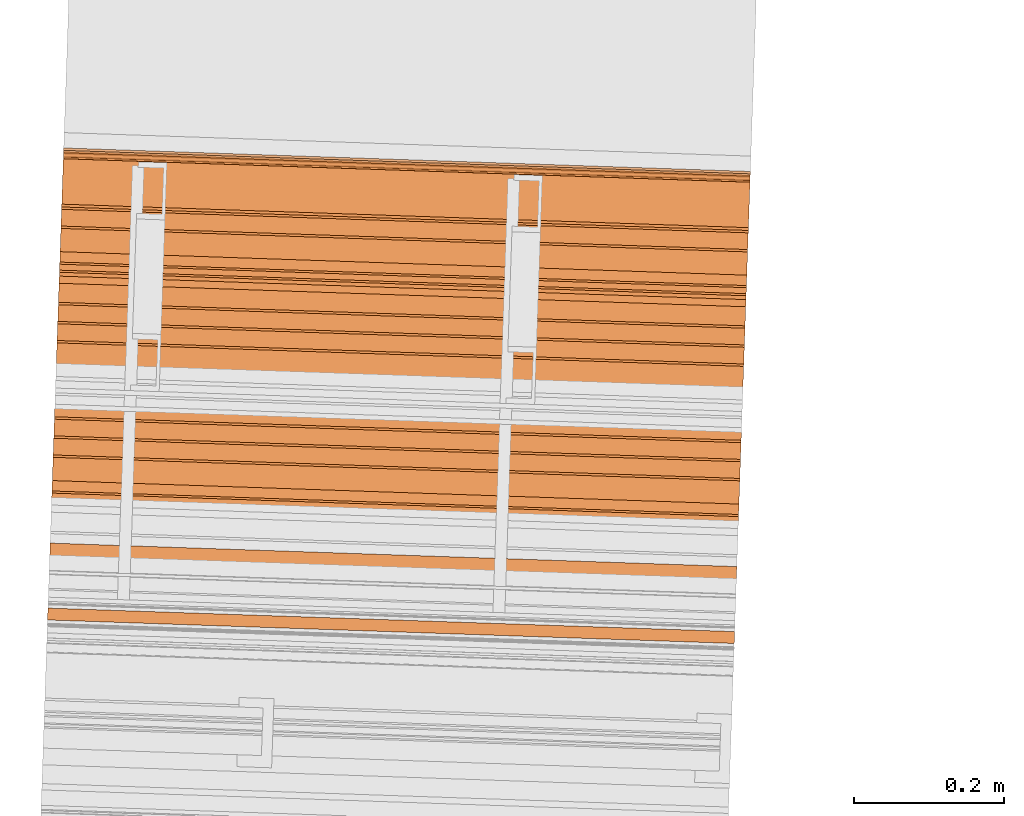
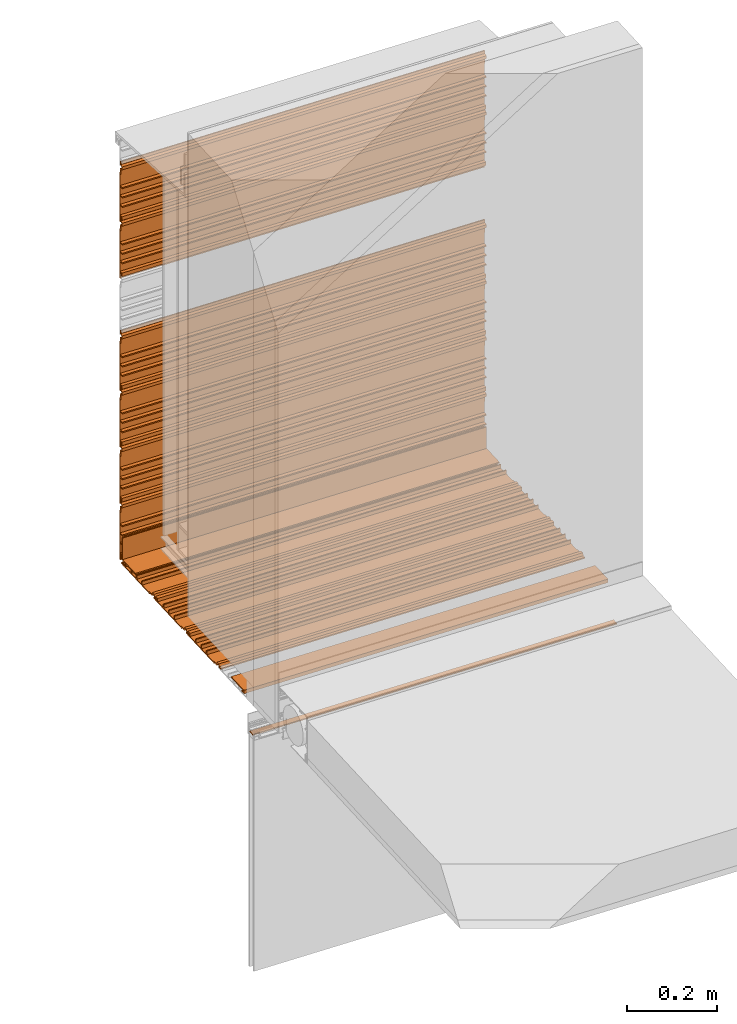
# One storey, part 10 of 36: 13 proxies.
"""IFC2X3 building model written with IfcOpenShell, lengths in feet."""

from ifc_helpers import new_model, entity, si_unit, converted_unit, derived_unit, direction, frame, frame_2d, origin, place, context, subcontext, project, spatial, polyline, circle_curve, parameter, trimmed, segment, composite_curve, outline, extrude, source, transform, mapped, material, type_object, type_shapes, element, save


model = new_model("IFC2X3")

# Units and contexts
model_context = context("Model", 3, precision=0.0001, world=origin(), true_north=direction((6.12303176911189e-17, 1.0)))
body_context = subcontext(model_context, "Body", "Model", "MODEL_VIEW")
ifc_project = project(units=[converted_unit("LENGTHUNIT", "FOOT", entity("IfcRatioMeasure", 0.3048), si_unit("LENGTHUNIT", "METRE"), dimensions=[1, 0, 0, 0, 0, 0, 0]), converted_unit("AREAUNIT", "SQUARE FOOT", entity("IfcRatioMeasure", 0.09290304), si_unit("AREAUNIT", "SQUARE_METRE"), dimensions=[2, 0, 0, 0, 0, 0, 0]), converted_unit("VOLUMEUNIT", "CUBIC FOOT", entity("IfcRatioMeasure", 0.028316846592), si_unit("VOLUMEUNIT", "CUBIC_METRE"), dimensions=[3, 0, 0, 0, 0, 0, 0]), converted_unit("PLANEANGLEUNIT", "DEGREE", entity("IfcRatioMeasure", 0.0174532925199433), si_unit("PLANEANGLEUNIT", "RADIAN"), dimensions=[0, 0, 0, 0, 0, 0, 0]), si_unit("MASSUNIT", "GRAM", prefix="KILO"), derived_unit("MASSDENSITYUNIT", [(si_unit("MASSUNIT", "GRAM", prefix="KILO"), 1), (si_unit("LENGTHUNIT", "METRE"), -3)]), si_unit("TIMEUNIT", "SECOND"), si_unit("FREQUENCYUNIT", "HERTZ"), si_unit("THERMODYNAMICTEMPERATUREUNIT", "DEGREE_CELSIUS"), derived_unit("THERMALTRANSMITTANCEUNIT", [(si_unit("MASSUNIT", "GRAM", prefix="KILO"), 1), (si_unit("THERMODYNAMICTEMPERATUREUNIT", "KELVIN"), -1), (si_unit("TIMEUNIT", "SECOND"), -3)]), derived_unit("VOLUMETRICFLOWRATEUNIT", [(si_unit("LENGTHUNIT", "METRE"), 3), (si_unit("TIMEUNIT", "SECOND"), -1)]), si_unit("ELECTRICCURRENTUNIT", "AMPERE"), si_unit("ELECTRICVOLTAGEUNIT", "VOLT"), si_unit("POWERUNIT", "WATT"), si_unit("FORCEUNIT", "NEWTON"), si_unit("ILLUMINANCEUNIT", "LUX"), si_unit("LUMINOUSFLUXUNIT", "LUMEN"), si_unit("LUMINOUSINTENSITYUNIT", "CANDELA"), derived_unit("USERDEFINED", [(si_unit("MASSUNIT", "GRAM", prefix="KILO"), -1), (si_unit("LENGTHUNIT", "METRE"), -2), (si_unit("TIMEUNIT", "SECOND"), 3), (si_unit("LUMINOUSFLUXUNIT", "LUMEN"), 1)]), derived_unit("LINEARVELOCITYUNIT", [(si_unit("LENGTHUNIT", "METRE"), 1), (si_unit("TIMEUNIT", "SECOND"), -1)]), si_unit("PRESSUREUNIT", "PASCAL"), derived_unit("USERDEFINED", [(si_unit("LENGTHUNIT", "METRE"), -2), (si_unit("MASSUNIT", "GRAM", prefix="KILO"), 1), (si_unit("TIMEUNIT", "SECOND"), -2)])], contexts=[model_context])

# Site, building, storey
site_placement = place(None, origin())
site = spatial("IfcSite", under=ifc_project, at=site_placement, CompositionType="ELEMENT")
building_placement = place(site_placement, origin())
building = spatial("IfcBuilding", under=site, at=building_placement, CompositionType="ELEMENT")
storey_placement = place(building_placement, origin())
storey = spatial("IfcBuildingStorey", under=building, at=storey_placement, Name="Level 1", CompositionType="ELEMENT", Elevation=0.0)

# Proxies
ifc_material_1 = material()
building_element_proxy_type_1 = type_object("IfcBuildingElementProxyType", Name="panel 018", PredefinedType="NOTDEFINED", material=ifc_material_1)
shared_shape_1 = source(origin(), body_context, "Body", "SweptSolid", [
    extrude(outline(polyline([(-0.291819852941191, -0.0116008650030945), (-0.291819852941191, -0.0220175316697464), (0.145680147058831, -0.0220175316697464), (0.145680147058831, -0.0116008650030945), (0.187346813725472, -0.0116008650030945), (0.195644309526004, 0.00619317207041625), (0.210299317924962, 0.00619317207041625), (0.218596813725494, -0.0116008650030945), (0.249846813725516, -0.0116008650030945), (0.249846813725516, -0.00118419833641603), (0.225232962281921, -0.00118419833641603), (0.21599402661919, 0.0186287629496658), (0.189949600831798, 0.0186287629496658), (0.180710665169066, -0.00118419833641603), (0.135263480392155, -0.00118419833641603), (0.135263480392155, -0.0116008650030945), (0.0337009803921422, -0.0116008650030945), (0.0337009803921422, 0.0196491349969126), (0.0232843137254944, 0.0196491349969126), (0.0232843137254944, -0.0116008650030945), (-0.0496323529411691, -0.0116008650030945), (-0.0496323529411691, 0.0196491349969126), (-0.0600490196078453, 0.0196491349969126), (-0.0600490196078453, -0.0116008650030945), (-0.132965686274508, -0.0116008650030945), (-0.132965686274508, 0.0196491349969126), (-0.143382352941185, 0.0196491349969126), (-0.143382352941185, -0.0116008650030945), (-0.226715686274524, -0.0116008650030945), (-0.226715686274524, 0.01730477312028), (-0.257965686274518, 0.01730477312028), (-0.257965686274518, 0.00451787023312988), (-0.237132352941172, 0.00451787023312988), (-0.237132352941172, -0.0116008650030945), (-0.291819852941191, -0.0116008650030945)])), frame((109.741606113486, -49.8662291822322, 9.73037350903194), z_axis=(-0.999414947916631, 0.0342017818365886, 0.0), x_axis=(-0.0342017818365886, -0.999414947916631, 0.0)), (0.0, 0.0, -1.0), 2.99999999999999),
])
type_shapes(building_element_proxy_type_1, [shared_shape_1])
proxy_1_placement = place(storey_placement, origin())
element("IfcBuildingElementProxy", 1, at=proxy_1_placement, inside=storey, type_object=building_element_proxy_type_1, material=ifc_material_1, Name="panel 018:panel 018", ObjectType="panel 018", context=body_context, shape_type="MappedRepresentation", body=[
    mapped(shared_shape_1, transform((0.0, 0.0, 0.0), scale=1.0)),
])
ifc_material_2 = material(Name="Window frame")
building_element_proxy_type_2 = type_object("IfcBuildingElementProxyType", Name="Window frame 013", PredefinedType="NOTDEFINED", material=ifc_material_2)
shared_shape_2 = source(origin(), body_context, "Body", "SweptSolid", [
    extrude(outline(composite_curve([segment(polyline([(-0.00499999999991374, -0.0259583333333165), (0.00499999999991552, -0.0259583333333165)]), True, "CONTINUOUS"), segment(polyline([(0.00499999999991552, -0.0259583333333165), (0.00499999999991552, 0.0259583333333232)]), True, "CONTINUOUS"), segment(polyline([(0.00499999999991552, 0.0259583333333232), (-0.00499999999991729, 0.0259583333333232)]), True, "CONTINUOUS"), segment(trimmed(circle_curve(frame_2d((-0.138517013888798, 0.0), x_axis=(0.0, 1.0)), 0.13601701388888), [parameter(258.997827097198)], [parameter(281.002172902812)], True, "PARAMETER"), False, "CONTINUOUS")], self_intersect=False)), frame((109.717039781299, -50.5840853372173, 9.44496783238198), z_axis=(0.999414947916633, -0.0342017818365487, 0.0), x_axis=(0.0, 0.0, 1.0)), (0.0, 0.0, 1.0), 3.0),
])
type_shapes(building_element_proxy_type_2, [shared_shape_2])
proxy_2_placement = place(storey_placement, origin())
element("IfcBuildingElementProxy", 2, at=proxy_2_placement, inside=storey, type_object=building_element_proxy_type_2, material=ifc_material_2, Name="Window frame 013:Window frame 013", ObjectType="Window frame 013", context=body_context, shape_type="MappedRepresentation", body=[
    mapped(shared_shape_2, transform((0.0, 0.0, 0.0), scale=1.0)),
])
building_element_proxy_type_3 = type_object("IfcBuildingElementProxyType", Name="panel 015", PredefinedType="NOTDEFINED", material=ifc_material_1)
shared_shape_3 = source(origin(), body_context, "Body", "SweptSolid", [
    extrude(outline(polyline([(-0.02201753168521, 0.145680147068472), (-0.02201753168521, -0.291819852931523), (-0.0116008650185618, -0.291819852931523), (-0.0116008650185618, -0.237132352931534), (0.00451787028329734, -0.237132352931534), (0.00451787028329734, -0.257965686264862), (0.0173047730392111, -0.257965686264862), (0.0173047730392111, -0.226715686264857), (-0.0116008650185618, -0.226715686264857), (-0.0116008650185618, -0.143382352931518), (0.0196491349814615, -0.143382352931518), (0.0196491349814615, -0.132965686264866), (-0.0116008650185618, -0.132965686264866), (-0.0116008650185618, -0.0600490195981802), (0.0196491349814615, -0.0600490195981802), (0.0196491349814615, -0.0496323529315283), (-0.0116008650185618, -0.0496323529315283), (-0.0116008650185618, 0.0232843137351342), (0.0196491349814615, 0.0232843137351342), (0.0196491349814615, 0.0337009804018091), (-0.0116008650185618, 0.0337009804018091), (-0.0116008650185618, 0.135263480401818), (-0.00118419835186385, 0.135263480401818), (-0.00118419835186385, 0.1807106651131), (0.018628763098251, 0.189949600808632), (0.018628763098251, 0.215994026661654), (-0.00118419835186385, 0.2252329620291), (-0.00118419835186385, 0.249846813735138), (-0.0116008650185618, 0.249846813735138), (-0.0116008650185618, 0.218596813735134), (0.0061931721533693, 0.210299318000235), (0.0061931721533693, 0.195644309470051), (-0.0116008650185618, 0.187346813735154), (-0.0116008650185618, 0.145680147068472), (-0.02201753168521, 0.145680147068472)])), frame((109.785926286855, -48.5711433305343, 10.521009163627), z_axis=(-0.999414947916598, 0.0342017818375703, 0.0), x_axis=(-0.0342017818375703, -0.999414947916598, 0.0)), (0.0, 0.0, -1.0), 2.99999999999999),
])
type_shapes(building_element_proxy_type_3, [shared_shape_3])
proxy_3_placement = place(storey_placement, origin())
element("IfcBuildingElementProxy", 3, at=proxy_3_placement, inside=storey, type_object=building_element_proxy_type_3, material=ifc_material_1, Name="panel 015:panel 015", ObjectType="panel 015", context=body_context, shape_type="MappedRepresentation", body=[
    mapped(shared_shape_3, transform((0.0, 0.0, 0.0), scale=1.0)),
])
building_element_proxy_type_4 = type_object("IfcBuildingElementProxyType", Name="panel 019", PredefinedType="NOTDEFINED", material=ifc_material_1)
shared_shape_4 = source(origin(), body_context, "Body", "SweptSolid", [
    extrude(outline(polyline([(-0.02201753168521, 0.145680147068473), (-0.02201753168521, -0.291819852931523), (-0.0116008650185618, -0.291819852931523), (-0.0116008650185618, -0.237132352931534), (0.00451787028329734, -0.237132352931534), (0.00451787028329734, -0.257965686264862), (0.0173047730392111, -0.257965686264862), (0.0173047730392111, -0.226715686264857), (-0.0116008650185618, -0.226715686264857), (-0.0116008650185618, -0.143382352931519), (0.0196491349814615, -0.143382352931519), (0.0196491349814615, -0.132965686264866), (-0.0116008650185618, -0.132965686264866), (-0.0116008650185618, -0.0600490195981802), (0.0196491349814615, -0.0600490195981802), (0.0196491349814615, -0.0496323529315283), (-0.0116008650185618, -0.0496323529315283), (-0.0116008650185618, 0.0232843137351342), (0.0196491349814615, 0.0232843137351342), (0.0196491349814615, 0.0337009804018091), (-0.0116008650185618, 0.0337009804018091), (-0.0116008650185618, 0.135263480401818), (-0.00118419835186385, 0.135263480401818), (-0.00118419835186385, 0.180710665113102), (0.018628763098251, 0.189949600808633), (0.018628763098251, 0.215994026661654), (-0.00118419835186385, 0.2252329620291), (-0.00118419835186385, 0.249846813735138), (-0.0116008650185618, 0.249846813735138), (-0.0116008650185618, 0.218596813735136), (0.0061931721533693, 0.210299318000235), (0.0061931721533693, 0.195644309470053), (-0.0116008650185618, 0.187346813735154), (-0.0116008650185618, 0.145680147068473), (-0.02201753168521, 0.145680147068473)])), frame((109.785926286855, -48.5711433305343, 13.021009163627), z_axis=(-0.999414947916598, 0.0342017818375703, 0.0), x_axis=(-0.0342017818375703, -0.999414947916598, 0.0)), (0.0, 0.0, -1.0), 2.99999999999999),
])
type_shapes(building_element_proxy_type_4, [shared_shape_4])
proxy_4_placement = place(storey_placement, origin())
element("IfcBuildingElementProxy", 4, at=proxy_4_placement, inside=storey, type_object=building_element_proxy_type_4, material=ifc_material_1, Name="panel 019:panel 019", ObjectType="panel 019", context=body_context, shape_type="MappedRepresentation", body=[
    mapped(shared_shape_4, transform((0.0, 0.0, 0.0), scale=1.0)),
])
building_element_proxy_type_5 = type_object("IfcBuildingElementProxyType", Name="panel 024", PredefinedType="NOTDEFINED", material=ifc_material_1)
shared_shape_5 = source(origin(), body_context, "Body", "SweptSolid", [
    extrude(outline(polyline([(-0.02201753168521, 0.145680147068473), (-0.02201753168521, -0.291819852931521), (-0.0116008650185618, -0.291819852931521), (-0.0116008650185618, -0.23713235293153), (0.00451787028329734, -0.23713235293153), (0.00451787028329734, -0.257965686264859), (0.0173047730392111, -0.257965686264859), (0.0173047730392111, -0.226715686264855), (-0.0116008650185618, -0.226715686264855), (-0.0116008650185618, -0.143382352931516), (0.0196491349814615, -0.143382352931516), (0.0196491349814615, -0.132965686264864), (-0.0116008650185618, -0.132965686264864), (-0.0116008650185618, -0.0600490195981767), (0.0196491349814615, -0.0600490195981767), (0.0196491349814615, -0.0496323529315266), (-0.0116008650185618, -0.0496323529315266), (-0.0116008650185618, 0.023284313735136), (0.0196491349814615, 0.023284313735136), (0.0196491349814615, 0.0337009804018127), (-0.0116008650185618, 0.0337009804018127), (-0.0116008650185618, 0.135263480401822), (-0.00118419835186385, 0.135263480401822), (-0.00118419835186385, 0.180710665113104), (0.018628763098251, 0.189949600808635), (0.018628763098251, 0.215994026661656), (-0.00118419835186385, 0.225232962029102), (-0.00118419835186385, 0.249846813735141), (-0.0116008650185618, 0.249846813735141), (-0.0116008650185618, 0.218596813735136), (0.0061931721533693, 0.210299318000239), (0.0061931721533693, 0.195644309470055), (-0.0116008650185618, 0.187346813735155), (-0.0116008650185618, 0.145680147068473), (-0.02201753168521, 0.145680147068473)])), frame((109.785926286855, -48.5711433305343, 10.021009163627), z_axis=(-0.999414947916598, 0.0342017818375703, 0.0), x_axis=(-0.0342017818375703, -0.999414947916598, 0.0)), (0.0, 0.0, -1.0), 2.99999999999999),
])
type_shapes(building_element_proxy_type_5, [shared_shape_5])
proxy_5_placement = place(storey_placement, origin())
element("IfcBuildingElementProxy", 5, at=proxy_5_placement, inside=storey, type_object=building_element_proxy_type_5, material=ifc_material_1, Name="panel 024:panel 024", ObjectType="panel 024", context=body_context, shape_type="MappedRepresentation", body=[
    mapped(shared_shape_5, transform((0.0, 0.0, 0.0), scale=1.0)),
])
building_element_proxy_type_6 = type_object("IfcBuildingElementProxyType", Name="panel 017", PredefinedType="NOTDEFINED", material=ifc_material_1)
shared_shape_6 = source(origin(), body_context, "Body", "SweptSolid", [
    extrude(outline(polyline([(-0.291819852941191, -0.0116008650030945), (-0.291819852941191, -0.0220175316697464), (0.145680147058824, -0.0220175316697464), (0.145680147058824, -0.0116008650030945), (0.187346813725472, -0.0116008650030945), (0.195644309526004, 0.00619317207041625), (0.210299317924955, 0.00619317207041625), (0.218596813725487, -0.0116008650030945), (0.249846813725509, -0.0116008650030945), (0.249846813725509, -0.00118419833641603), (0.225232962281921, -0.00118419833641603), (0.21599402661919, 0.0186287629496658), (0.189949600831798, 0.0186287629496658), (0.180710665169066, -0.00118419833641603), (0.135263480392155, -0.00118419833641603), (0.135263480392155, -0.0116008650030945), (0.0337009803921422, -0.0116008650030945), (0.0337009803921422, 0.0196491349969126), (0.0232843137254873, 0.0196491349969126), (0.0232843137254873, -0.0116008650030945), (-0.0496323529411762, -0.0116008650030945), (-0.0496323529411762, 0.0196491349969126), (-0.0600490196078453, 0.0196491349969126), (-0.0600490196078453, -0.0116008650030945), (-0.132965686274515, -0.0116008650030945), (-0.132965686274515, 0.0196491349969126), (-0.143382352941185, 0.0196491349969126), (-0.143382352941185, -0.0116008650030945), (-0.226715686274524, -0.0116008650030945), (-0.226715686274524, 0.01730477312028), (-0.257965686274525, 0.01730477312028), (-0.257965686274525, 0.00451787023312988), (-0.237132352941179, 0.00451787023312988), (-0.237132352941179, -0.0116008650030945), (-0.291819852941191, -0.0116008650030945)])), frame((109.758707004404, -49.3665217082739, 9.73037350903194), z_axis=(-0.999414947916631, 0.034201781836593, 0.0), x_axis=(-0.034201781836593, -0.999414947916631, 0.0)), (0.0, 0.0, -1.0), 2.99999999999999),
])
type_shapes(building_element_proxy_type_6, [shared_shape_6])
proxy_6_placement = place(storey_placement, origin())
element("IfcBuildingElementProxy", 6, at=proxy_6_placement, inside=storey, type_object=building_element_proxy_type_6, material=ifc_material_1, Name="panel 017:panel 017", ObjectType="panel 017", context=body_context, shape_type="MappedRepresentation", body=[
    mapped(shared_shape_6, transform((0.0, 0.0, 0.0), scale=1.0)),
])
building_element_proxy_type_7 = type_object("IfcBuildingElementProxyType", Name="panel 014", PredefinedType="NOTDEFINED", material=ifc_material_1)
shared_shape_7 = source(origin(), body_context, "Body", "SweptSolid", [
    extrude(outline(polyline([(-0.02201753168521, 0.145680147068472), (-0.02201753168521, -0.291819852931521), (-0.0116008650185618, -0.291819852931521), (-0.0116008650185618, -0.237132352931532), (0.00451787028329734, -0.237132352931532), (0.00451787028329734, -0.25796568626486), (0.0173047730392111, -0.25796568626486), (0.0173047730392111, -0.226715686264857), (-0.0116008650185618, -0.226715686264857), (-0.0116008650185618, -0.143382352931518), (0.0196491349814615, -0.143382352931518), (0.0196491349814615, -0.132965686264864), (-0.0116008650185618, -0.132965686264864), (-0.0116008650185618, -0.0600490195981784), (0.0196491349814615, -0.0600490195981784), (0.0196491349814615, -0.0496323529315283), (-0.0116008650185618, -0.0496323529315283), (-0.0116008650185618, 0.023284313735136), (0.0196491349814615, 0.023284313735136), (0.0196491349814615, 0.0337009804018109), (-0.0116008650185618, 0.0337009804018109), (-0.0116008650185618, 0.13526348040182), (-0.00118419835186385, 0.13526348040182), (-0.00118419835186385, 0.180710665113102), (0.018628763098251, 0.189949600808633), (0.018628763098251, 0.215994026661654), (-0.00118419835186385, 0.2252329620291), (-0.00118419835186385, 0.24984681373514), (-0.0116008650185618, 0.24984681373514), (-0.0116008650185618, 0.218596813735136), (0.0061931721533693, 0.210299318000237), (0.0061931721533693, 0.195644309470053), (-0.0116008650185618, 0.187346813735154), (-0.0116008650185618, 0.145680147068472), (-0.02201753168521, 0.145680147068472)])), frame((109.785926286855, -48.5711433305343, 11.521009163627), z_axis=(-0.999414947916598, 0.0342017818375703, 0.0), x_axis=(-0.0342017818375703, -0.999414947916598, 0.0)), (0.0, 0.0, -1.0), 2.99999999999999),
])
type_shapes(building_element_proxy_type_7, [shared_shape_7])
proxy_7_placement = place(storey_placement, origin())
element("IfcBuildingElementProxy", 7, at=proxy_7_placement, inside=storey, type_object=building_element_proxy_type_7, material=ifc_material_1, Name="panel 014:panel 014", ObjectType="panel 014", context=body_context, shape_type="MappedRepresentation", body=[
    mapped(shared_shape_7, transform((0.0, 0.0, 0.0), scale=1.0)),
])
building_element_proxy_type_8 = type_object("IfcBuildingElementProxyType", Name="panel 016", PredefinedType="NOTDEFINED", material=ifc_material_1)
shared_shape_8 = source(origin(), body_context, "Body", "SweptSolid", [
    extrude(outline(polyline([(-0.291819852941184, -0.0116008650030945), (-0.291819852941184, -0.0220175316697464), (0.145680147058831, -0.0220175316697464), (0.145680147058831, -0.0116008650030945), (0.187346813725479, -0.0116008650030945), (0.195644309526011, 0.00619317207041625), (0.210299317924962, 0.00619317207041625), (0.218596813725494, -0.0116008650030945), (0.249846813725516, -0.0116008650030945), (0.249846813725516, -0.00118419833641603), (0.225232962281928, -0.00118419833641603), (0.21599402661919, 0.0186287629496658), (0.189949600831805, 0.0186287629496658), (0.180710665169073, -0.00118419833641603), (0.135263480392155, -0.00118419833641603), (0.135263480392155, -0.0116008650030945), (0.0337009803921493, -0.0116008650030945), (0.0337009803921493, 0.0196491349969126), (0.0232843137254944, 0.0196491349969126), (0.0232843137254944, -0.0116008650030945), (-0.0496323529411691, -0.0116008650030945), (-0.0496323529411691, 0.0196491349969126), (-0.0600490196078453, 0.0196491349969126), (-0.0600490196078453, -0.0116008650030945), (-0.132965686274508, -0.0116008650030945), (-0.132965686274508, 0.0196491349969126), (-0.143382352941185, 0.0196491349969126), (-0.143382352941185, -0.0116008650030945), (-0.226715686274517, -0.0116008650030945), (-0.226715686274517, 0.01730477312028), (-0.257965686274518, 0.01730477312028), (-0.257965686274518, 0.00451787023312988), (-0.237132352941172, 0.00451787023312988), (-0.237132352941172, -0.0116008650030945), (-0.291819852941184, -0.0116008650030945)])), frame((109.775807895323, -48.8668142343156, 9.73037350903194), z_axis=(-0.999414947916631, 0.034201781836593, 0.0), x_axis=(-0.034201781836593, -0.999414947916631, 0.0)), (0.0, 0.0, -1.0), 2.99999999999999),
])
type_shapes(building_element_proxy_type_8, [shared_shape_8])
proxy_8_placement = place(storey_placement, origin())
element("IfcBuildingElementProxy", 8, at=proxy_8_placement, inside=storey, type_object=building_element_proxy_type_8, material=ifc_material_1, Name="panel 016:panel 016", ObjectType="panel 016", context=body_context, shape_type="MappedRepresentation", body=[
    mapped(shared_shape_8, transform((0.0, 0.0, 0.0), scale=1.0)),
])
building_element_proxy_type_9 = type_object("IfcBuildingElementProxyType", Name="panel 023", PredefinedType="NOTDEFINED", material=ifc_material_1)
shared_shape_9 = source(origin(), body_context, "Body", "SweptSolid", [
    extrude(outline(polyline([(-0.02201753168521, 0.145680147068472), (-0.02201753168521, -0.291819852931523), (-0.0116008650185618, -0.291819852931523), (-0.0116008650185618, -0.237132352931534), (0.00451787028329734, -0.237132352931534), (0.00451787028329734, -0.257965686264862), (0.0173047730392111, -0.257965686264862), (0.0173047730392111, -0.226715686264857), (-0.0116008650185618, -0.226715686264857), (-0.0116008650185618, -0.143382352931519), (0.0196491349814615, -0.143382352931519), (0.0196491349814615, -0.132965686264866), (-0.0116008650185618, -0.132965686264866), (-0.0116008650185618, -0.0600490195981802), (0.0196491349814615, -0.0600490195981802), (0.0196491349814615, -0.0496323529315283), (-0.0116008650185618, -0.0496323529315283), (-0.0116008650185618, 0.0232843137351342), (0.0196491349814615, 0.0232843137351342), (0.0196491349814615, 0.0337009804018091), (-0.0116008650185618, 0.0337009804018091), (-0.0116008650185618, 0.135263480401818), (-0.00118419835186385, 0.135263480401818), (-0.00118419835186385, 0.1807106651131), (0.018628763098251, 0.189949600808632), (0.018628763098251, 0.215994026661653), (-0.00118419835186385, 0.2252329620291), (-0.00118419835186385, 0.249846813735138), (-0.0116008650185618, 0.249846813735138), (-0.0116008650185618, 0.218596813735134), (0.0061931721533693, 0.210299318000235), (0.0061931721533693, 0.195644309470051), (-0.0116008650185618, 0.187346813735154), (-0.0116008650185618, 0.145680147068472), (-0.02201753168521, 0.145680147068472)])), frame((109.785926286855, -48.5711433305343, 11.021009163627), z_axis=(-0.999414947916598, 0.0342017818375703, 0.0), x_axis=(-0.0342017818375703, -0.999414947916598, 0.0)), (0.0, 0.0, -1.0), 2.99999999999999),
])
type_shapes(building_element_proxy_type_9, [shared_shape_9])
proxy_9_placement = place(storey_placement, origin())
element("IfcBuildingElementProxy", 9, at=proxy_9_placement, inside=storey, type_object=building_element_proxy_type_9, material=ifc_material_1, Name="panel 023:panel 023", ObjectType="panel 023", context=body_context, shape_type="MappedRepresentation", body=[
    mapped(shared_shape_9, transform((0.0, 0.0, 0.0), scale=1.0)),
])
ifc_material_3 = material(Name="Metallic support for window frame")
building_element_proxy_type_10 = type_object("IfcBuildingElementProxyType", Name="starter strip 006", PredefinedType="NOTDEFINED", material=ifc_material_3)
shared_shape_10 = source(origin(), body_context, "Body", "SweptSolid", [
    extrude(outline(polyline([(-0.00592609117455451, -0.050489778625332), (-0.00592609117455451, -0.0251609571030134), (-0.0154211444225842, -0.0251609571030134), (-0.0154211444225842, -0.0613594856463298), (0.0159630966207279, -0.0613594856463298), (0.0159630966207279, 0.137010221374673), (0.00538413897638247, 0.137010221374673), (0.00538413897638247, -0.050489778625332), (-0.00592609117455451, -0.050489778625332)])), frame((109.785617492212, -48.580166661063, 9.81008004634182), z_axis=(-0.999414947916684, 0.0342017818350489, 0.0), x_axis=(-0.0342017818350489, -0.999414947916684, 0.0)), (0.0, 0.0, -1.0), 3.00000000000001),
])
type_shapes(building_element_proxy_type_10, [shared_shape_10])
proxy_10_placement = place(storey_placement, origin())
element("IfcBuildingElementProxy", 10, at=proxy_10_placement, inside=storey, type_object=building_element_proxy_type_10, material=ifc_material_3, Name="starter strip 006:starter strip 006", ObjectType="starter strip 006", context=body_context, shape_type="MappedRepresentation", body=[
    mapped(shared_shape_10, transform((0.0, 0.0, 0.0), scale=1.0)),
])
building_element_proxy_type_11 = type_object("IfcBuildingElementProxyType", Name="panel 013", PredefinedType="NOTDEFINED", material=ifc_material_1)
shared_shape_11 = source(origin(), body_context, "Body", "SweptSolid", [
    extrude(outline(polyline([(-0.02201753168521, 0.14568014706847), (-0.02201753168521, -0.291819852931525), (-0.0116008650185618, -0.291819852931525), (-0.0116008650185618, -0.237132352931534), (0.00451787028329734, -0.237132352931534), (0.00451787028329734, -0.257965686264862), (0.0173047730392111, -0.257965686264862), (0.0173047730392111, -0.226715686264859), (-0.0116008650185618, -0.226715686264859), (-0.0116008650185618, -0.143382352931519), (0.0196491349814615, -0.143382352931519), (0.0196491349814615, -0.132965686264868), (-0.0116008650185618, -0.132965686264868), (-0.0116008650185618, -0.0600490195981802), (0.0196491349814615, -0.0600490195981802), (0.0196491349814615, -0.0496323529315301), (-0.0116008650185618, -0.0496323529315301), (-0.0116008650185618, 0.0232843137351324), (0.0196491349814615, 0.0232843137351324), (0.0196491349814615, 0.0337009804018091), (-0.0116008650185618, 0.0337009804018091), (-0.0116008650185618, 0.135263480401818), (-0.00118419835186385, 0.135263480401818), (-0.00118419835186385, 0.1807106651131), (0.018628763098251, 0.189949600808632), (0.018628763098251, 0.215994026661653), (-0.00118419835186385, 0.225232962029098), (-0.00118419835186385, 0.249846813735138), (-0.0116008650185618, 0.249846813735138), (-0.0116008650185618, 0.218596813735132), (0.0061931721533693, 0.210299318000235), (0.0061931721533693, 0.195644309470051), (-0.0116008650185618, 0.187346813735152), (-0.0116008650185618, 0.14568014706847), (-0.02201753168521, 0.14568014706847)])), frame((109.785926286855, -48.5711433305343, 12.521009163627), z_axis=(-0.999414947916598, 0.0342017818375703, 0.0), x_axis=(-0.0342017818375703, -0.999414947916598, 0.0)), (0.0, 0.0, -1.0), 2.99999999999999),
])
type_shapes(building_element_proxy_type_11, [shared_shape_11])
proxy_11_placement = place(storey_placement, origin())
element("IfcBuildingElementProxy", 11, at=proxy_11_placement, inside=storey, type_object=building_element_proxy_type_11, material=ifc_material_1, Name="panel 013:panel 013", ObjectType="panel 013", context=body_context, shape_type="MappedRepresentation", body=[
    mapped(shared_shape_11, transform((0.0, 0.0, 0.0), scale=1.0)),
])
building_element_proxy_type_12 = type_object("IfcBuildingElementProxyType", Name="starter strip 004", PredefinedType="NOTDEFINED", material=ifc_material_3)
shared_shape_12 = source(origin(), body_context, "Body", "SweptSolid", [
    extrude(outline(polyline([(-0.0154211442749244, -0.0613594857283263), (0.0159630965387141, -0.0613594857283263), (0.0159630965387141, 0.137010221423891), (0.0053841388615421, 0.137010221423891), (0.0053841388615421, -0.050489778576132), (-0.00592609112533005, -0.050489778576132), (-0.00592609112533005, -0.0251609571194247), (-0.0154211442749244, -0.0251609571194247), (-0.0154211442749244, -0.0613594857283263)])), frame((109.782968627618, -48.6575694958939, 9.74081747039039), z_axis=(0.999414947916643, -0.0342017818362344, 0.0), x_axis=(0.0, 0.0, 1.0)), (0.0, 0.0, 1.0), 3.0),
])
type_shapes(building_element_proxy_type_12, [shared_shape_12])
proxy_12_placement = place(storey_placement, origin())
element("IfcBuildingElementProxy", 12, at=proxy_12_placement, inside=storey, type_object=building_element_proxy_type_12, material=ifc_material_3, Name="starter strip 004:starter strip 004", ObjectType="starter strip 004", context=body_context, shape_type="MappedRepresentation", body=[
    mapped(shared_shape_12, transform((0.0, 0.0, 0.0), scale=1.0)),
])
building_element_proxy_type_13 = type_object("IfcBuildingElementProxyType", Name="starter strip 005", PredefinedType="NOTDEFINED", material=ifc_material_3)
shared_shape_13 = source(origin(), body_context, "Body", "SweptSolid", [
    extrude(outline(polyline([(-0.00592609117455467, -0.0504897786253382), (-0.00592609117455467, -0.0251609571030165), (-0.0154211444225663, -0.0251609571030165), (-0.0154211444225663, -0.0613594856463326), (0.0159630966207374, -0.0613594856463326), (0.0159630966207374, 0.137010221374673), (0.00538413897638002, 0.137010221374673), (0.00538413897638002, -0.0504897786253382), (-0.00592609117455467, -0.0504897786253382)])), frame((109.722955483838, -50.4112217837229, 9.7408174703082), z_axis=(-0.999414947916628, 0.0342017818366741, 0.0), x_axis=(0.0, 0.0, 1.0)), (0.0, 0.0, -1.0), 3.0),
])
type_shapes(building_element_proxy_type_13, [shared_shape_13])
proxy_13_placement = place(storey_placement, origin())
element("IfcBuildingElementProxy", 13, at=proxy_13_placement, inside=storey, type_object=building_element_proxy_type_13, material=ifc_material_3, Name="starter strip 005:starter strip 005", ObjectType="starter strip 005", context=body_context, shape_type="MappedRepresentation", body=[
    mapped(shared_shape_13, transform((0.0, 0.0, 0.0), scale=1.0)),
])

save(model, "model.ifc")
